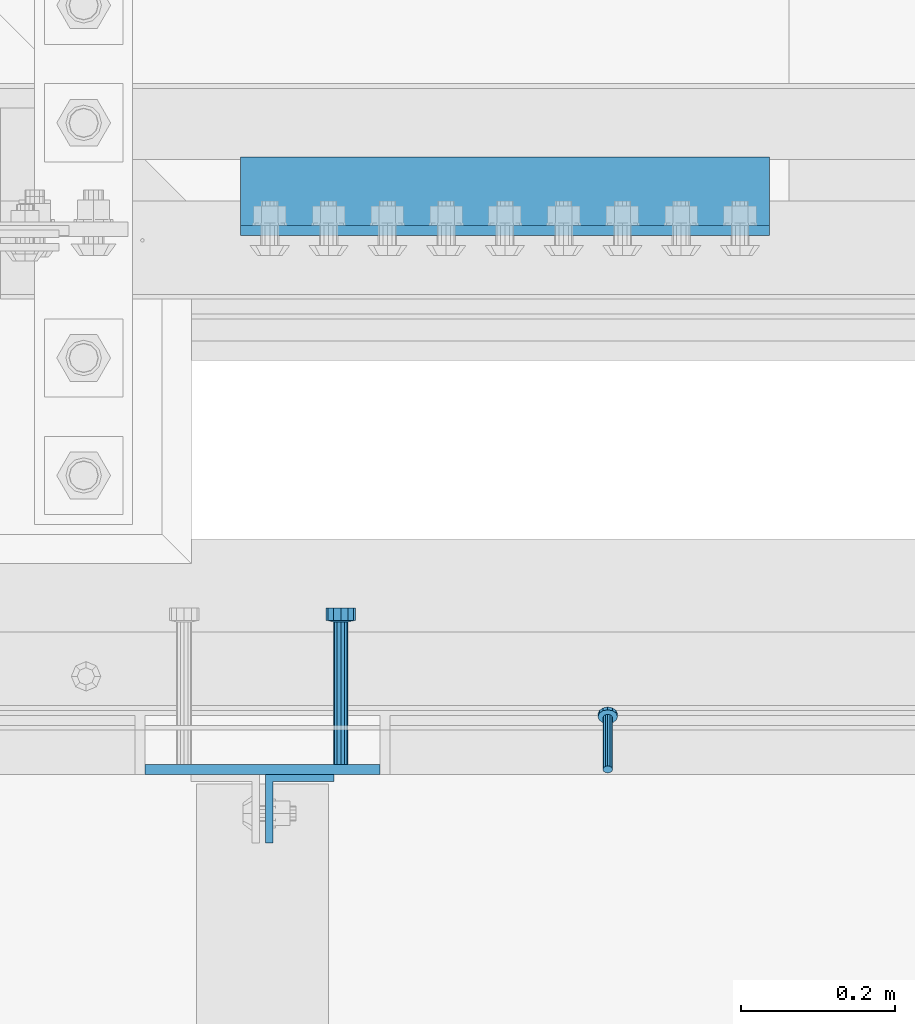
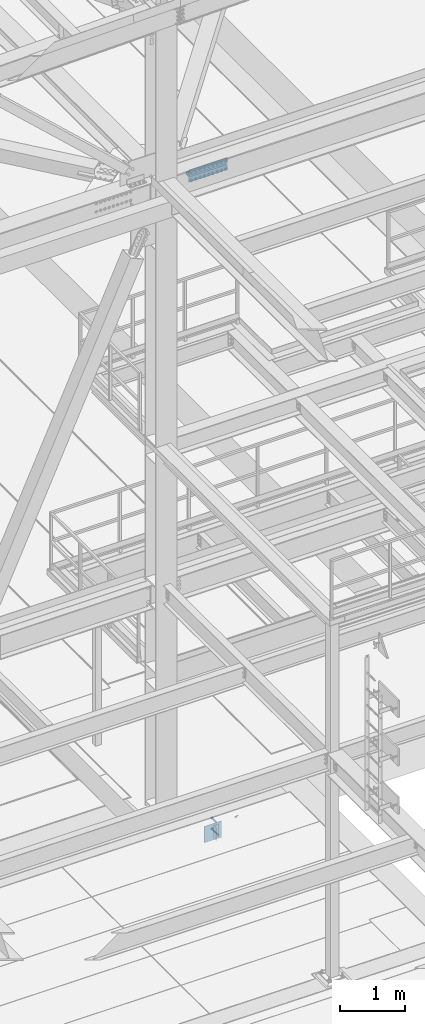
# One storey, part 2113 of 3843: 6 beams, 1 member, 4 elements without a shape of their own.
"""IFC2X3 building model written with IfcOpenShell, lengths in millimetres."""

from ifc_helpers import new_model, si_unit, frame, origin_with_axes, place, context, subcontext, project, spatial, faceted_brep, material, type_object, element, aggregate, save


model = new_model("IFC2X3")

# Units and contexts
model_context = context("Model", 3, precision=1e-05, world=origin_with_axes())
body_context = subcontext(model_context, "Body", "Model", "MODEL_VIEW")
ifc_project = project(units=[si_unit("LENGTHUNIT", "METRE", prefix="MILLI"), si_unit("AREAUNIT", "SQUARE_METRE"), si_unit("VOLUMEUNIT", "CUBIC_METRE"), si_unit("MASSUNIT", "GRAM", prefix="KILO"), si_unit("TIMEUNIT", "SECOND"), si_unit("PLANEANGLEUNIT", "RADIAN"), si_unit("SOLIDANGLEUNIT", "STERADIAN"), si_unit("THERMODYNAMICTEMPERATUREUNIT", "DEGREE_CELSIUS"), si_unit("LUMINOUSINTENSITYUNIT", "LUMEN")], contexts=[model_context])

# Site, building, storey
site_placement = place(None, origin_with_axes())
site = spatial("IfcSite", under=ifc_project, at=site_placement, CompositionType="ELEMENT")
building_placement = place(site_placement, origin_with_axes())
building = spatial("IfcBuilding", under=site, at=building_placement, Name="Undefined", CompositionType="ELEMENT")
storey_placement = place(building_placement, origin_with_axes())
storey = spatial("IfcBuildingStorey", under=building, at=storey_placement, Name="Undefined", CompositionType="ELEMENT", Elevation=0.0)

# Assembly, member
assembly_1_placement = place(storey_placement, origin_with_axes())
assembly_1 = element("IfcElementAssembly", 1, at=assembly_1_placement, inside=storey, Name="ANGLE", AssemblyPlace="NOTDEFINED", PredefinedType="RIGID_FRAME")
ifc_material_1 = material(Name="STEEL/A108")
member_type = type_object("IfcMemberType", PredefinedType="NOTDEFINED")
member_placement = place(assembly_1_placement, frame((49980.8414794922, 24930.099999999, 30397.4500030518), z_axis=(-1.0, 0.0, 0.0), x_axis=(5.70000238222118e-08, 0.707106781186546, -0.707106781186546)))
member = element("IfcMember", 2, at=member_placement, type_object=member_type, material=ifc_material_1, Name="HEADED STUD ANCHOR", context=body_context, shape_type="Brep", body=[
    faceted_brep([(7.27595761418343e-12, -3.18000006675175, 5.5), (0.0, -5.49999999998363, 3.1800000667572), (94.4879985803855, -5.50000000011278, 3.1800000667572), (94.4879985803782, -3.18000006687362, 5.5), (0.0, -6.3499999046162, 0.0), (94.4879985803855, -6.34999990474535, 0.0), (0.0, -5.49999999998363, -3.1800000667572), (94.4879985803855, -5.50000000011278, -3.1800000667572), (7.27595761418343e-12, -3.18000006675175, -5.5), (94.4879985803782, -3.18000006687362, -5.5), (7.27595761418343e-12, -1.81898940354586e-12, -6.34999990463257), (94.4879985803782, -1.20053300634027e-10, -6.34999990463257), (0.0, 3.18000006675175, -5.5), (94.4879985803709, 3.18000006663351, -5.5), (7.27595761418343e-12, 5.49999999998363, -3.1800000667572), (94.4879985803709, 5.49999999987267, -3.1800000667572), (7.27595761418343e-12, 6.3499999046162, 0.0), (94.4879985803673, 6.34999990450706, 0.0), (7.27595761418343e-12, 5.49999999998363, 3.1800000667572), (94.4879985803709, 5.49999999987267, 3.1800000667572), (0.0, 3.18000006675175, 5.5), (94.4879985803709, 3.18000006663351, 5.5), (7.27595761418343e-12, -1.81898940354586e-12, 6.34999990463257), (94.4879985803782, -1.20053300634027e-10, 6.34999990463257), (96.5199985498621, -10.9899997712273, 6.34999990463257), (96.5199985498548, -6.34000015270249, 10.9899997711182), (96.5199985498621, -12.6999998093743, 0.0), (96.5199985498621, -10.9899997712273, -6.34999990463257), (96.5199985498548, -6.34000015270249, -10.9899997711182), (96.5199985498475, -1.21872290037572e-10, -12.6899995803833), (96.5199985498402, 6.34000015245874, -10.9899997711182), (96.519998549833, 10.9899997709817, -6.34999990463257), (96.519998549833, 12.6999998091305, 0.0), (96.519998549833, 10.9899997709817, 6.34999990463257), (96.5199985498402, 6.34000015245874, 10.9899997711182), (96.5199985498475, -1.21872290037572e-10, 12.6899995803833), (101.599998473539, -10.9899997712328, 6.34999990463257), (101.599998473532, -6.34000015270976, 10.9899997711182), (101.599998473539, -12.6999998093797, 0.0), (101.599998473539, -10.9899997712328, -6.34999990463257), (101.599998473532, -6.34000015270976, -10.9899997711182), (101.599998473524, -1.29148247651756e-10, -12.6899995803833), (101.599998473517, 6.34000015245329, -10.9899997711182), (101.59999847351, 10.9899997709763, -6.34999990463257), (101.599998473503, 12.6999998091196, 0.0), (101.59999847351, 10.9899997709763, 6.34999990463257), (101.599998473517, 6.34000015245329, 10.9899997711182), (101.599998473524, -1.29148247651756e-10, 12.6899995803833)], [[[0, 1, 2, 3]], [[1, 4, 5, 2]], [[4, 6, 7, 5]], [[6, 8, 9, 7]], [[8, 10, 11, 9]], [[10, 12, 13, 11]], [[12, 14, 15, 13]], [[14, 16, 17, 15]], [[16, 18, 19, 17]], [[18, 20, 21, 19]], [[20, 22, 23, 21]], [[22, 0, 3, 23]], [[22, 20, 18, 16, 14, 12, 10, 8, 6, 4, 1, 0]], [[3, 2, 24, 25]], [[2, 5, 26, 24]], [[5, 7, 27, 26]], [[7, 9, 28, 27]], [[9, 11, 29, 28]], [[11, 13, 30, 29]], [[13, 15, 31, 30]], [[15, 17, 32, 31]], [[17, 19, 33, 32]], [[19, 21, 34, 33]], [[21, 23, 35, 34]], [[23, 3, 25, 35]], [[25, 24, 36, 37]], [[24, 26, 38, 36]], [[26, 27, 39, 38]], [[27, 28, 40, 39]], [[28, 29, 41, 40]], [[29, 30, 42, 41]], [[30, 31, 43, 42]], [[31, 32, 44, 43]], [[32, 33, 45, 44]], [[33, 34, 46, 45]], [[34, 35, 47, 46]], [[35, 25, 37, 47]], [[38, 39, 40, 41, 42, 43, 44, 45, 46, 47, 37, 36]]]),
])
aggregate(assembly_1, [member])

# Assembly, beam
assembly_2_placement = place(storey_placement, origin_with_axes())
assembly_2 = element("IfcElementAssembly", 3, at=assembly_2_placement, inside=storey, Name="EMBED PLATE", AssemblyPlace="NOTDEFINED", PredefinedType="RIGID_FRAME")
ifc_material_2 = material(Name="STEEL/A36")
beam_type_1 = type_object("IfcBeamType", PredefinedType="NOTDEFINED")
beam_1_placement = place(assembly_2_placement, frame((49533.175, 24930.0999969483, 30397.45), z_axis=(1.0, 0.0, 0.0), x_axis=(0.0, 0.0, -1.0)))
beam_1 = element("IfcBeam", 4, at=beam_1_placement, type_object=beam_type_1, material=ifc_material_2, Name="EMBED PLATE", context=body_context, shape_type="Brep", body=[
    faceted_brep([(-1.0550138540566e-10, 6.34999999999854, -152.400000000664), (1.0550138540566e-10, 6.34999999999854, 152.400000000656), (304.799999999999, 6.34999999999854, 152.400000000001), (304.799999999999, 6.34999999999854, -152.400000000001), (1.0550138540566e-10, -6.34999999999854, 152.400000000656), (304.799999999999, -6.34999999999854, 152.400000000001), (-1.0550138540566e-10, -6.34999999999854, -152.400000000664), (304.799999999999, -6.34999999999854, -152.400000000001)], [[[0, 1, 2, 3]], [[1, 4, 5, 2]], [[4, 6, 7, 5]], [[6, 0, 3, 7]], [[5, 7, 3, 2]], [[6, 4, 1, 0]]]),
])

# Assembly, beams
assembly_3_placement = place(storey_placement, origin_with_axes())
assembly_3 = element("IfcElementAssembly", 5, at=assembly_3_placement, inside=storey, Name="PLATE", AssemblyPlace="NOTDEFINED", PredefinedType="RIGID_FRAME")
ifc_material_3 = material(Name="STEEL/A572-50")
beam_type_2 = type_object("IfcBeamType", Name="L4X4X1/2", PredefinedType="NOTDEFINED")
beam_2_placement = place(assembly_3_placement, frame((49504.5999999996, 25673.0500000017, 42297.35), z_axis=(0.0, 1.0, 0.0), x_axis=(1.0, 0.0, 0.0)))
beam_2 = element("IfcBeam", 6, at=beam_2_placement, type_object=beam_type_2, material=ifc_material_3, Name="ANGLE", ObjectType="L4X4X1/2", context=body_context, shape_type="Brep", body=[
    faceted_brep([(0.0, 50.8000000000029, -50.8000000000029), (0.0, 50.8000000000029, 50.8000000000029), (685.800000000003, 50.8000000000029, 50.8000000000029), (685.800000000003, 50.8000000000029, -50.8000000000029), (0.0, 38.0999999999985, 50.8000000000029), (685.800000000003, 38.0999999999985, 50.8000000000029), (0.0, 38.0999999999985, -38.0999999999985), (685.800000000003, 38.0999999999985, -38.1000000000058), (0.0, -50.8000000000029, -38.1000000000058), (685.800000000003, -50.8000000000029, -38.1000000000058), (0.0, -50.8000000000029, -50.8000000000029), (685.800000000003, -50.8000000000029, -50.8000000000029)], [[[0, 1, 2, 3]], [[1, 4, 5, 2]], [[4, 6, 7, 5]], [[6, 8, 9, 7]], [[8, 10, 11, 9]], [[10, 0, 3, 11]], [[5, 7, 9, 11, 3, 2]], [[10, 8, 6, 4, 1, 0]]]),
])
beam_3_placement = place(assembly_3_placement, frame((50190.3999999996, 25673.0500000067, 42167.175), z_axis=(0.0, 1.0, 0.0), x_axis=(-1.0, 0.0, 0.0)))
beam_3 = element("IfcBeam", 7, at=beam_3_placement, type_object=beam_type_2, material=ifc_material_3, Name="ANGLE", ObjectType="L4X4X1/2", context=body_context, shape_type="Brep", body=[
    faceted_brep([(0.0, 50.8000000000029, -50.8000000000029), (0.0, 50.8000000000029, 50.8000000000029), (685.800000000003, 50.8000000000029, 50.8000000000029), (685.800000000003, 50.8000000000029, -50.8000000000029), (0.0, 38.0999999999985, 50.8000000000029), (685.800000000003, 38.0999999999985, 50.8000000000029), (0.0, 38.0999999999985, -38.0999999999985), (685.800000000003, 38.0999999999985, -38.1000000000058), (0.0, -50.8000000000029, -38.1000000000058), (685.800000000003, -50.8000000000029, -38.1000000000058), (0.0, -50.8000000000029, -50.8000000000029), (685.800000000003, -50.8000000000029, -50.8000000000029)], [[[0, 1, 2, 3]], [[1, 4, 5, 2]], [[4, 6, 7, 5]], [[6, 8, 9, 7]], [[8, 10, 11, 9]], [[10, 0, 3, 11]], [[5, 7, 9, 11, 3, 2]], [[10, 8, 6, 4, 1, 0]]]),
])
aggregate(assembly_3, [beam_2, beam_3])

# Assembly, beam
assembly_4_placement = place(storey_placement, origin_with_axes())
assembly_4 = element("IfcElementAssembly", 8, at=assembly_4_placement, inside=storey, Name="BEAM", AssemblyPlace="NOTDEFINED", PredefinedType="RIGID_FRAME")
beam_type_3 = type_object("IfcBeamType", Name="L3-1/2X3-1/2X3/8", PredefinedType="NOTDEFINED")
beam_4_placement = place(assembly_4_placement, frame((49581.59375, 24879.2999969483, 30365.7), z_axis=(1.0, 0.0, 0.0), x_axis=(0.0, 0.0, -1.0)))
beam_4 = element("IfcBeam", 9, at=beam_4_placement, type_object=beam_type_3, material=ifc_material_2, Name="ANGLE", ObjectType="L3-1/2X3-1/2X3/8", context=body_context, shape_type="Brep", body=[
    faceted_brep([(-3.63797880709171e-12, 44.4499999999971, -44.4500000000007), (-3.63797880709171e-12, 44.4499999999971, 44.4500000000007), (228.600000000006, 44.4499999999971, 44.4500000000007), (228.600000000006, 44.4499999999971, -44.4500000000007), (0.0, 34.9250000000029, 44.4500000000007), (228.600000000006, 34.9250000000029, 44.4500000000007), (0.0, 34.9250000000029, -34.9250000000029), (228.600000000006, 34.9250000000029, -34.9249999999993), (0.0, -44.4499999999971, -34.9249999999993), (228.600000000006, -44.4499999999971, -34.9249999999993), (3.63797880709171e-12, -44.4499999999971, -44.4500000000007), (228.600000000006, -44.4499999999971, -44.4500000000007)], [[[0, 1, 2, 3]], [[1, 4, 5, 2]], [[4, 6, 7, 5]], [[6, 8, 9, 7]], [[8, 10, 11, 9]], [[10, 0, 3, 11]], [[5, 7, 9, 11, 3, 2]], [[10, 8, 6, 4, 1, 0]]]),
])
aggregate(assembly_4, [beam_4])

# Beam
beam_type_4 = type_object("IfcBeamType", PredefinedType="NOTDEFINED")
beam_5_placement = place(assembly_2_placement, frame((49634.775, 24936.4499969483, 30346.65), z_axis=(-1.0, 0.0, 0.0), x_axis=(0.0, 1.0, 0.0)))
beam_5 = element("IfcBeam", 10, at=beam_5_placement, type_object=beam_type_4, material=ifc_material_2, Name="PLATE", context=body_context, shape_type="Brep", body=[
    faceted_brep([(0.0, -9.52000045776367, 0.0), (0.0, -8.25, -4.76000022888184), (184.912000000004, -8.25, -4.76000022888184), (184.912000000004, -9.52000045776367, 0.0), (0.0, -4.76000022888184, -8.25), (184.912000000004, -4.76000022888184, -8.25), (0.0, 0.0, -9.52000045776367), (184.912000000004, 0.0, -9.52000045776367), (0.0, 4.76000022888184, -8.25), (184.912000000004, 4.76000022888184, -8.25), (0.0, 8.25, -4.76000022888184), (184.912000000004, 8.25, -4.76000022888184), (0.0, 9.52000045776367, 0.0), (184.912000000004, 9.52000045776367, 0.0), (0.0, 8.25, 4.76000022888184), (184.912000000004, 8.25, 4.76000022888184), (0.0, 4.76000022888184, 8.25), (184.912000000004, 4.76000022888184, 8.25), (0.0, 0.0, 9.52000045776367), (184.912000000004, 0.0, 9.52000045776367), (0.0, -4.76000022888184, 8.25), (184.912000000004, -4.76000022888184, 8.25), (0.0, -8.25, 4.76000022888184), (184.912000000004, -8.25, 4.76000022888184), (186.944000000003, -16.5, -9.52000045776367), (186.944000000003, -19.0499992370605, 0.0), (186.944000000003, -9.52000045776367, -16.5), (186.944000000003, 0.0, -19.0499992370605), (186.944000000003, 9.52000045776367, -16.5), (186.944000000003, 16.5, -9.52000045776367), (186.944000000003, 19.0499992370605, 0.0), (186.944000000003, 16.5, 9.52000045776367), (186.944000000003, 9.52000045776367, 16.5), (186.944000000003, 0.0, 19.0499992370605), (186.944000000003, -9.52000045776367, 16.5), (186.944000000003, -16.5, 9.52000045776367), (203.199999999997, -16.5, -9.52000045776367), (203.199999999997, -19.0499992370605, 0.0), (203.199999999997, -9.52000045776367, -16.5), (203.199999999997, 0.0, -19.0499992370605), (203.199999999997, 9.52000045776367, -16.5), (203.199999999997, 16.5, -9.52000045776367), (203.199999999997, 19.0499992370605, 0.0), (203.199999999997, 16.5, 9.52000045776367), (203.199999999997, 9.52000045776367, 16.5), (203.199999999997, 0.0, 19.0499992370605), (203.199999999997, -9.52000045776367, 16.5), (203.199999999997, -16.5, 9.52000045776367)], [[[0, 1, 2, 3]], [[1, 4, 5, 2]], [[4, 6, 7, 5]], [[6, 8, 9, 7]], [[8, 10, 11, 9]], [[10, 12, 13, 11]], [[12, 14, 15, 13]], [[14, 16, 17, 15]], [[16, 18, 19, 17]], [[18, 20, 21, 19]], [[20, 22, 23, 21]], [[22, 0, 3, 23]], [[22, 20, 18, 16, 14, 12, 10, 8, 6, 4, 1, 0]], [[3, 2, 24, 25]], [[2, 5, 26, 24]], [[5, 7, 27, 26]], [[7, 9, 28, 27]], [[9, 11, 29, 28]], [[11, 13, 30, 29]], [[13, 15, 31, 30]], [[15, 17, 32, 31]], [[17, 19, 33, 32]], [[19, 21, 34, 33]], [[21, 23, 35, 34]], [[23, 3, 25, 35]], [[25, 24, 36, 37]], [[24, 26, 38, 36]], [[26, 27, 39, 38]], [[27, 28, 40, 39]], [[28, 29, 41, 40]], [[29, 30, 42, 41]], [[30, 31, 43, 42]], [[31, 32, 44, 43]], [[32, 33, 45, 44]], [[33, 34, 46, 45]], [[34, 35, 47, 46]], [[35, 25, 37, 47]], [[38, 39, 40, 41, 42, 43, 44, 45, 46, 47, 37, 36]]]),
])

beam_6_placement = place(assembly_2_placement, frame((49634.775, 24936.4499969483, 30143.45), z_axis=(-1.0, 0.0, 0.0), x_axis=(0.0, 1.0, 0.0)))
beam_6 = element("IfcBeam", 11, at=beam_6_placement, type_object=beam_type_4, material=ifc_material_1, Name="HEADED STUD ANCHOR", context=body_context, shape_type="Brep", body=[
    faceted_brep([(0.0, -9.52000045776367, 0.0), (0.0, -8.25, -4.76000022888184), (184.912000000004, -8.25, -4.76000022888184), (184.912000000004, -9.52000045776367, 0.0), (0.0, -4.76000022888184, -8.25), (184.912000000004, -4.76000022888184, -8.25), (0.0, 0.0, -9.52000045776367), (184.912000000004, 0.0, -9.52000045776367), (0.0, 4.76000022888184, -8.25), (184.912000000004, 4.76000022888184, -8.25), (0.0, 8.25, -4.76000022888184), (184.912000000004, 8.25, -4.76000022888184), (0.0, 9.52000045776367, 0.0), (184.912000000004, 9.52000045776367, 0.0), (0.0, 8.25, 4.76000022888184), (184.912000000004, 8.25, 4.76000022888184), (0.0, 4.76000022888184, 8.25), (184.912000000004, 4.76000022888184, 8.25), (0.0, 0.0, 9.52000045776367), (184.912000000004, 0.0, 9.52000045776367), (0.0, -4.76000022888184, 8.25), (184.912000000004, -4.76000022888184, 8.25), (0.0, -8.25, 4.76000022888184), (184.912000000004, -8.25, 4.76000022888184), (186.944000000003, -16.5, -9.52000045776367), (186.944000000003, -19.0499992370605, 0.0), (186.944000000003, -9.52000045776367, -16.5), (186.944000000003, 0.0, -19.0499992370605), (186.944000000003, 9.52000045776367, -16.5), (186.944000000003, 16.5, -9.52000045776367), (186.944000000003, 19.0499992370605, 0.0), (186.944000000003, 16.5, 9.52000045776367), (186.944000000003, 9.52000045776367, 16.5), (186.944000000003, 0.0, 19.0499992370605), (186.944000000003, -9.52000045776367, 16.5), (186.944000000003, -16.5, 9.52000045776367), (203.199999999997, -16.5, -9.52000045776367), (203.199999999997, -19.0499992370605, 0.0), (203.199999999997, -9.52000045776367, -16.5), (203.199999999997, 0.0, -19.0499992370605), (203.199999999997, 9.52000045776367, -16.5), (203.199999999997, 16.5, -9.52000045776367), (203.199999999997, 19.0499992370605, 0.0), (203.199999999997, 16.5, 9.52000045776367), (203.199999999997, 9.52000045776367, 16.5), (203.199999999997, 0.0, 19.0499992370605), (203.199999999997, -9.52000045776367, 16.5), (203.199999999997, -16.5, 9.52000045776367)], [[[0, 1, 2, 3]], [[1, 4, 5, 2]], [[4, 6, 7, 5]], [[6, 8, 9, 7]], [[8, 10, 11, 9]], [[10, 12, 13, 11]], [[12, 14, 15, 13]], [[14, 16, 17, 15]], [[16, 18, 19, 17]], [[18, 20, 21, 19]], [[20, 22, 23, 21]], [[22, 0, 3, 23]], [[22, 20, 18, 16, 14, 12, 10, 8, 6, 4, 1, 0]], [[3, 2, 24, 25]], [[2, 5, 26, 24]], [[5, 7, 27, 26]], [[7, 9, 28, 27]], [[9, 11, 29, 28]], [[11, 13, 30, 29]], [[13, 15, 31, 30]], [[15, 17, 32, 31]], [[17, 19, 33, 32]], [[19, 21, 34, 33]], [[21, 23, 35, 34]], [[23, 3, 25, 35]], [[25, 24, 36, 37]], [[24, 26, 38, 36]], [[26, 27, 39, 38]], [[27, 28, 40, 39]], [[28, 29, 41, 40]], [[29, 30, 42, 41]], [[30, 31, 43, 42]], [[31, 32, 44, 43]], [[32, 33, 45, 44]], [[33, 34, 46, 45]], [[34, 35, 47, 46]], [[35, 25, 37, 47]], [[38, 39, 40, 41, 42, 43, 44, 45, 46, 47, 37, 36]]]),
])

aggregate(assembly_2, [beam_5, beam_6, beam_1])

save(model, "model.ifc")
